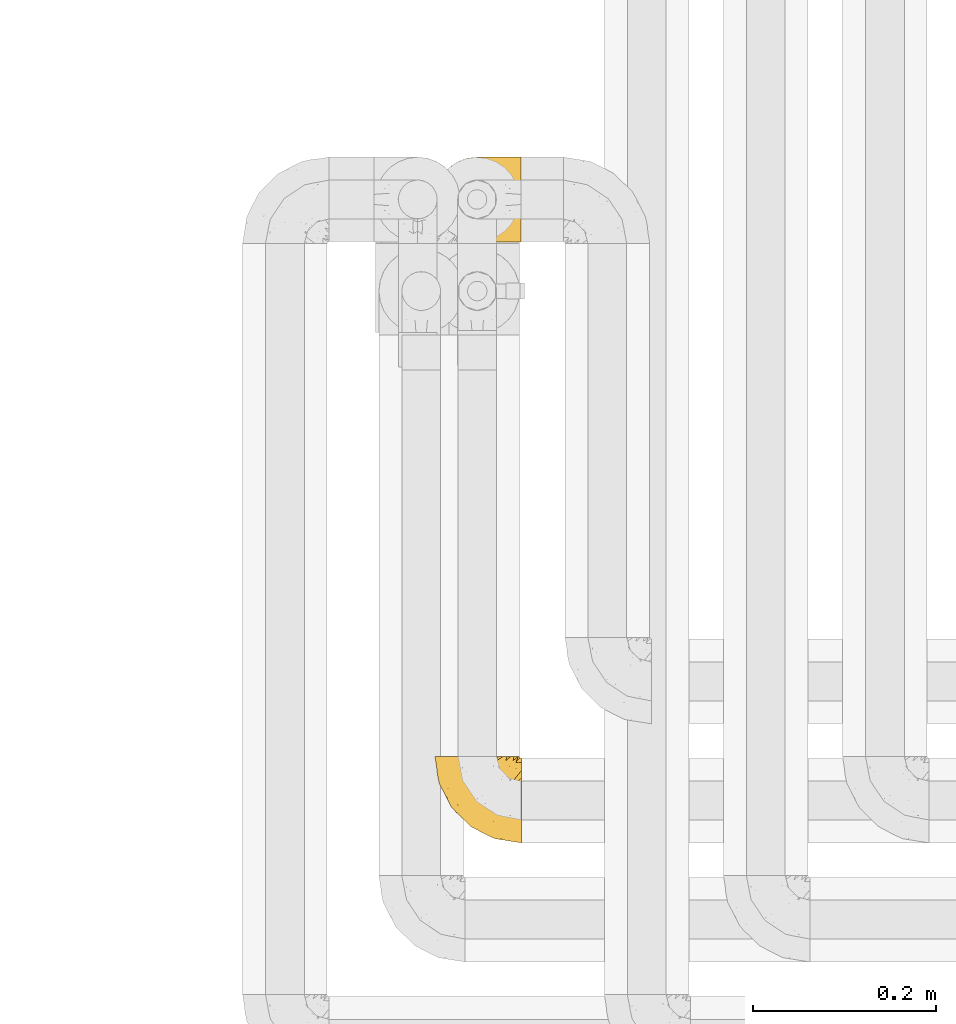
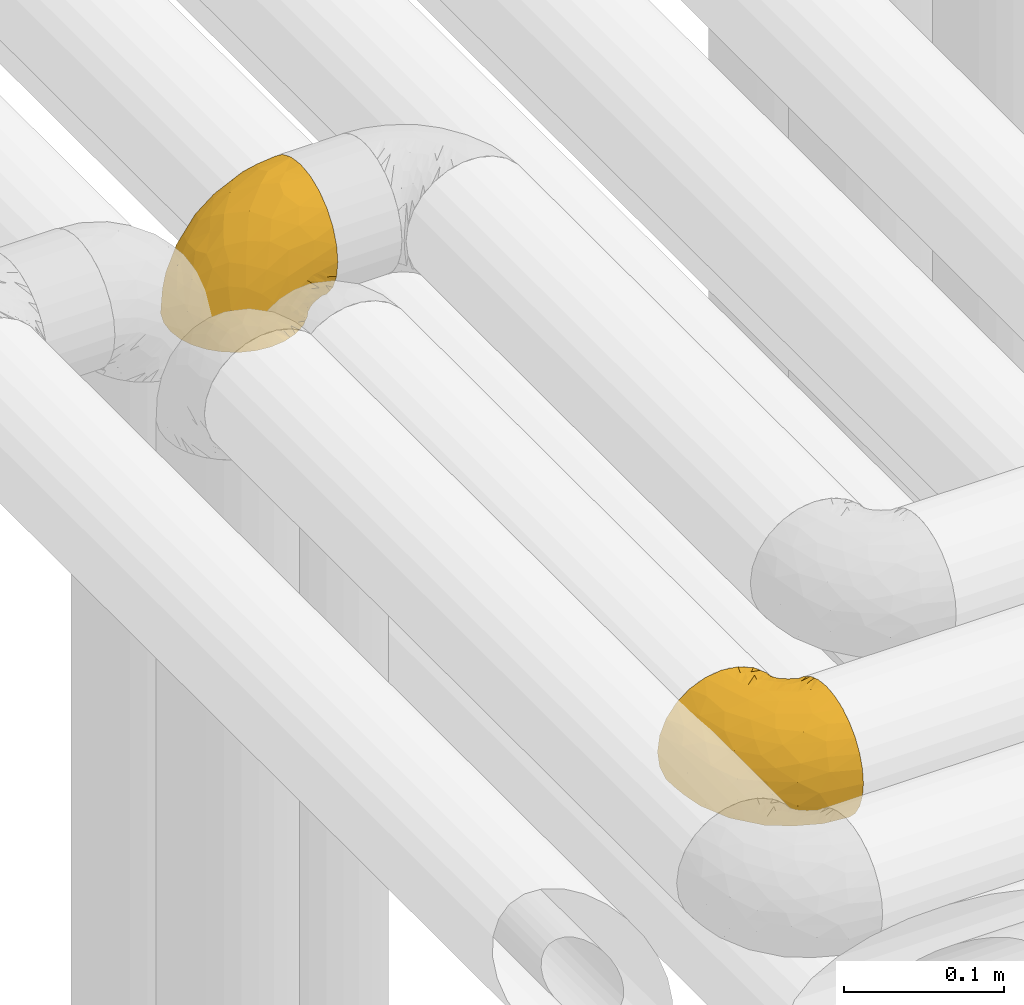
# One storey, part 236 of 827: 2 coverings.
"""IFC2X3 building model written with IfcOpenShell, lengths in millimetres."""

from ifc_helpers import new_model, entity, si_unit, converted_unit, derived_unit, direction, frame, origin, place, context, subcontext, project, spatial, faceted_brep, element, save


model = new_model("IFC2X3")

# Units and contexts
model_context = context("Model", 3, precision=0.01, world=origin(), true_north=direction((6.12303176911189e-17, 1.0)))
body_context = subcontext(model_context, "Body", "Model", "MODEL_VIEW")
ifc_project = project(units=[si_unit("LENGTHUNIT", "METRE", prefix="MILLI"), si_unit("AREAUNIT", "SQUARE_METRE"), si_unit("VOLUMEUNIT", "CUBIC_METRE"), converted_unit("PLANEANGLEUNIT", "DEGREE", entity("IfcRatioMeasure", 0.0174532925199433), si_unit("PLANEANGLEUNIT", "RADIAN"), dimensions=[0, 0, 0, 0, 0, 0, 0]), si_unit("MASSUNIT", "GRAM", prefix="KILO"), derived_unit("MASSDENSITYUNIT", [(si_unit("MASSUNIT", "GRAM", prefix="KILO"), 1), (si_unit("LENGTHUNIT", "METRE"), -3)]), derived_unit("MOMENTOFINERTIAUNIT", [(si_unit("LENGTHUNIT", "METRE"), 4)]), si_unit("TIMEUNIT", "SECOND"), si_unit("FREQUENCYUNIT", "HERTZ"), si_unit("THERMODYNAMICTEMPERATUREUNIT", "DEGREE_CELSIUS"), derived_unit("THERMALTRANSMITTANCEUNIT", [(si_unit("MASSUNIT", "GRAM", prefix="KILO"), 1), (si_unit("THERMODYNAMICTEMPERATUREUNIT", "KELVIN"), -1), (si_unit("TIMEUNIT", "SECOND"), -3)]), derived_unit("VOLUMETRICFLOWRATEUNIT", [(si_unit("LENGTHUNIT", "METRE"), 3), (si_unit("TIMEUNIT", "SECOND"), -1)]), derived_unit("MASSFLOWRATEUNIT", [(si_unit("MASSUNIT", "GRAM", prefix="KILO"), 1), (si_unit("TIMEUNIT", "SECOND"), -1)]), derived_unit("ROTATIONALFREQUENCYUNIT", [(si_unit("TIMEUNIT", "SECOND"), -1)]), si_unit("ELECTRICCURRENTUNIT", "AMPERE"), si_unit("ELECTRICVOLTAGEUNIT", "VOLT"), si_unit("POWERUNIT", "WATT"), si_unit("FORCEUNIT", "NEWTON", prefix="KILO"), si_unit("ILLUMINANCEUNIT", "LUX"), si_unit("LUMINOUSFLUXUNIT", "LUMEN"), si_unit("LUMINOUSINTENSITYUNIT", "CANDELA"), derived_unit("USERDEFINED", [(si_unit("MASSUNIT", "GRAM", prefix="KILO"), -1), (si_unit("LENGTHUNIT", "METRE"), -2), (si_unit("TIMEUNIT", "SECOND"), 3), (si_unit("LUMINOUSFLUXUNIT", "LUMEN"), 1)]), derived_unit("LINEARVELOCITYUNIT", [(si_unit("LENGTHUNIT", "METRE"), 1), (si_unit("TIMEUNIT", "SECOND"), -1)]), si_unit("PRESSUREUNIT", "PASCAL"), derived_unit("USERDEFINED", [(si_unit("LENGTHUNIT", "METRE"), -2), (si_unit("MASSUNIT", "GRAM", prefix="KILO"), 1), (si_unit("TIMEUNIT", "SECOND"), -2)]), derived_unit("LINEARFORCEUNIT", [(si_unit("MASSUNIT", "GRAM", prefix="KILO"), 1), (si_unit("LENGTHUNIT", "METRE"), 1), (si_unit("TIMEUNIT", "SECOND"), -2), (si_unit("LENGTHUNIT", "METRE"), -1)]), derived_unit("PLANARFORCEUNIT", [(si_unit("MASSUNIT", "GRAM", prefix="KILO"), 1), (si_unit("LENGTHUNIT", "METRE"), 1), (si_unit("TIMEUNIT", "SECOND"), -2), (si_unit("LENGTHUNIT", "METRE"), -2)])], contexts=[model_context])

# Site, building, storey
site_placement = place(None, origin())
site = spatial("IfcSite", under=ifc_project, at=site_placement, CompositionType="ELEMENT")
building_placement = place(site_placement, origin())
building = spatial("IfcBuilding", under=site, at=building_placement, CompositionType="ELEMENT")
storey_placement = place(building_placement, frame((0.0, 0.0, 28200.0)))
storey = spatial("IfcBuildingStorey", under=building, at=storey_placement, Name="08", CompositionType="ELEMENT", Elevation=28200.0)

# Coverings
covering_1_placement = place(storey_placement, frame((30683.75, 14312.21, 3352.2)))
element("IfcCovering", 1, at=covering_1_placement, inside=storey, Name=":ADSK_", ObjectType=":ADSK_", PredefinedType="INSULATION", context=body_context, shape_type="Brep", body=[
    faceted_brep([(95.8, 18.98, 83.91), (95.8, 11.67, 76.59), (95.8, 6.17, 67.83), (95.8, 2.75, 58.07), (95.8, 1.6, 47.8), (95.8, 2.75, 37.51), (95.8, 6.17, 27.74), (95.8, 11.68, 18.98), (95.8, 19.0, 11.67), (95.8, 27.76, 6.17), (95.8, 37.52, 2.75), (95.8, 47.8, 1.6), (95.8, 51.94, 2.06), (95.8, 55.01, 2.41), (95.8, 58.08, 2.75), (95.8, 62.96, 4.46), (95.8, 67.85, 6.17), (95.8, 72.23, 8.93), (95.8, 76.61, 11.68), (95.8, 80.26, 15.34), (95.8, 83.92, 19.0), (95.8, 89.42, 27.76), (95.8, 91.13, 32.64), (95.8, 92.84, 37.52), (95.8, 94.0, 47.8), (95.8, 92.84, 58.08), (95.8, 91.13, 62.96), (95.8, 89.42, 67.85), (95.8, 83.91, 76.61), (95.8, 80.25, 80.26), (95.8, 76.59, 83.92), (95.8, 72.21, 86.67), (95.8, 67.83, 89.42), (95.8, 62.95, 91.13), (95.8, 58.07, 92.84), (95.8, 55.0, 93.18), (95.8, 51.94, 93.53), (95.8, 47.8, 94.0), (95.8, 37.51, 92.84), (95.8, 27.74, 89.42), (94.0, 95.8, 47.8), (92.42, 95.8, 35.84), (87.81, 95.8, 24.7), (84.13, 95.8, 19.91), (80.46, 95.8, 15.13), (75.68, 95.8, 11.46), (70.9, 95.8, 7.78), (65.32, 95.8, 5.48), (59.75, 95.8, 3.17), (56.14, 95.8, 2.69), (54.06, 95.8, 2.42), (51.97, 95.8, 2.14), (47.8, 95.8, 1.6), (35.84, 95.8, 3.17), (24.7, 95.8, 7.78), (15.13, 95.8, 15.13), (7.78, 95.8, 24.7), (3.17, 95.8, 35.84), (1.6, 95.8, 47.8), (3.17, 95.8, 59.75), (7.78, 95.8, 70.9), (15.13, 95.8, 80.46), (24.7, 95.8, 87.81), (35.84, 95.8, 92.42), (47.8, 95.8, 94.0), (51.97, 95.8, 93.45), (56.14, 95.8, 92.9), (59.75, 95.8, 92.42), (65.32, 95.8, 90.11), (70.9, 95.8, 87.81), (75.68, 95.8, 84.13), (80.46, 95.8, 80.46), (84.13, 95.8, 75.68), (87.81, 95.8, 70.9), (92.42, 95.8, 59.75), (15.84, 60.58, 71.98), (6.99, 74.11, 63.6), (14.39, 51.59, 59.72), (6.21, 66.69, 47.8), (4.26, 76.19, 55.16), (3.39, 84.43, 47.8), (31.2, 31.2, 63.76), (26.47, 42.88, 72.22), (11.44, 79.41, 74.18), (47.66, 60.7, 92.52), (61.85, 61.85, 94.0), (59.25, 65.75, 94.0), (56.65, 69.64, 94.0), (54.05, 73.53, 94.0), (51.45, 77.43, 94.0), (19.8, 74.59, 82.14), (26.22, 54.72, 80.34), (31.58, 64.18, 87.52), (38.36, 37.94, 79.59), (51.54, 25.89, 78.25), (51.6, 34.73, 85.01), (55.97, 42.89, 90.25), (62.88, 49.83, 93.2), (41.35, 48.58, 87.23), (82.24, 22.41, 85.55), (40.88, 78.69, 93.0), (29.0, 81.64, 89.31), (74.06, 6.22, 61.31), (54.53, 12.11, 56.86), (57.98, 14.81, 68.34), (43.81, 21.61, 65.71), (38.22, 22.41, 56.99), (38.33, 30.12, 72.15), (74.76, 10.01, 70.34), (76.85, 15.36, 78.36), (84.43, 3.39, 47.8), (40.43, 19.59, 47.8), (30.01, 30.01, 47.8), (78.67, 41.19, 93.06), (92.06, 48.54, 94.0), (88.32, 49.28, 94.0), (85.6, 49.82, 94.0), (82.88, 50.37, 94.0), (80.15, 50.91, 94.0), (77.43, 51.45, 94.0), (76.36, 31.61, 89.88), (50.91, 80.15, 94.0), (50.37, 82.88, 94.0), (49.82, 85.6, 94.0), (49.28, 88.32, 94.0), (48.91, 90.19, 94.0), (48.54, 92.06, 94.0), (66.69, 6.21, 47.8), (73.53, 54.05, 94.0), (69.64, 56.65, 94.0), (65.75, 59.25, 94.0), (66.13, 24.66, 83.7), (19.59, 40.43, 47.8), (24.64, 35.17, 55.9), (53.56, 12.9, 47.8), (12.9, 53.56, 47.8), (82.81, 85.34, 81.75), (81.22, 78.44, 86.43), (86.57, 84.37, 79.8), (92.75, 89.05, 69.84), (89.68, 82.76, 79.5), (72.26, 86.31, 88.08), (64.73, 83.73, 91.6), (62.45, 77.31, 92.93), (60.63, 87.78, 92.43), (56.91, 87.91, 93.24), (58.14, 81.29, 93.36), (93.7, 93.97, 57.25), (83.4, 70.76, 89.41), (75.54, 63.67, 92.89), (79.46, 62.62, 92.66), (82.28, 90.64, 79.58), (76.25, 84.08, 86.51), (90.18, 77.45, 83.91), (84.69, 76.28, 86.29), (65.12, 88.72, 90.94), (71.71, 71.28, 91.94), (75.21, 68.09, 91.98), (78.6, 91.07, 82.79), (87.27, 57.47, 93.16), (87.92, 70.34, 88.76), (86.94, 91.35, 73.94), (86.1, 62.99, 91.89), (94.52, 94.52, 47.8), (66.23, 76.47, 92.22), (91.08, 69.96, 88.56), (71.77, 89.86, 87.72), (76.21, 78.94, 88.33), (68.59, 73.51, 92.18), (89.94, 89.62, 71.78), (76.22, 78.96, 7.27), (81.22, 78.46, 9.17), (71.7, 71.31, 3.66), (48.54, 92.06, 1.6), (50.37, 82.88, 1.6), (49.82, 85.6, 1.6), (49.28, 88.32, 1.6), (93.7, 93.97, 38.35), (89.95, 89.63, 23.84), (82.88, 50.37, 1.6), (85.6, 49.82, 1.6), (92.06, 48.54, 1.6), (88.32, 49.28, 1.6), (89.68, 82.77, 16.1), (87.92, 70.36, 6.84), (62.45, 77.31, 2.66), (66.24, 76.47, 3.37), (56.65, 69.64, 1.6), (59.25, 65.75, 1.6), (78.6, 91.06, 12.8), (60.63, 87.78, 3.16), (56.91, 87.91, 2.35), (92.76, 89.06, 25.77), (76.25, 84.09, 9.09), (82.28, 90.65, 16.02), (82.81, 85.35, 13.85), (54.05, 73.53, 1.6), (51.45, 77.43, 1.6), (58.14, 81.29, 2.23), (90.18, 77.46, 11.69), (84.7, 76.29, 9.31), (87.25, 57.47, 2.43), (75.58, 63.71, 2.71), (75.2, 68.11, 3.61), (83.39, 70.77, 6.18), (90.73, 69.52, 6.77), (79.47, 62.64, 2.93), (86.94, 91.35, 21.66), (65.75, 59.25, 1.6), (86.75, 84.6, 16.09), (86.08, 62.98, 3.7), (77.43, 51.45, 1.6), (73.53, 54.05, 1.6), (69.64, 56.65, 1.6), (64.73, 83.73, 3.99), (50.91, 80.15, 1.6), (65.12, 88.72, 4.65), (72.26, 86.3, 7.51), (61.85, 61.85, 1.6), (68.62, 73.56, 3.43), (74.03, 91.36, 9.46), (80.15, 50.91, 1.6), (49.81, 62.87, 2.4), (4.26, 76.19, 40.43), (19.95, 73.57, 13.57), (30.61, 56.07, 11.3), (25.71, 49.77, 18.65), (22.43, 44.73, 27.26), (15.85, 60.58, 23.61), (60.69, 47.64, 3.07), (40.49, 78.32, 2.69), (14.39, 51.59, 35.87), (6.99, 74.11, 31.99), (29.56, 76.04, 6.71), (11.45, 79.41, 21.41), (57.98, 14.82, 27.24), (74.06, 6.22, 34.26), (54.52, 12.12, 38.73), (43.47, 23.51, 26.97), (31.2, 31.2, 31.83), (33.27, 34.96, 23.4), (64.26, 33.86, 6.91), (74.29, 38.94, 3.4), (80.41, 30.23, 5.84), (24.64, 35.17, 39.69), (73.62, 15.85, 17.6), (78.98, 22.59, 10.38), (53.69, 21.56, 20.6), (42.86, 55.94, 5.36), (41.67, 20.67, 35.73), (79.66, 9.19, 24.84), (58.41, 25.79, 13.87), (47.11, 41.16, 9.06), (38.37, 37.95, 15.99)], [[[0, 1, 2, 3, 4, 5, 6, 7, 8, 9, 10, 11, 12, 13, 14, 15, 16, 17, 18, 19, 20, 21, 22, 23, 24, 25, 26, 27, 28, 29, 30, 31, 32, 33, 34, 35, 36, 37, 38, 39]], [[40, 41, 42, 43, 44, 45, 46, 47, 48, 49, 50, 51, 52, 53, 54, 55, 56, 57, 58, 59, 60, 61, 62, 63, 64, 65, 66, 67, 68, 69, 70, 71, 72, 73, 74]], [[75, 76, 77]], [[78, 79, 80]], [[77, 81, 82]], [[76, 75, 83]], [[84, 85, 86, 87, 88, 89]], [[90, 91, 92]], [[76, 60, 59]], [[93, 94, 95]], [[90, 62, 61]], [[83, 61, 60]], [[96, 97, 84]], [[98, 93, 95]], [[0, 39, 99]], [[100, 84, 89]], [[62, 101, 63]], [[2, 102, 3]], [[92, 84, 100]], [[103, 102, 104]], [[103, 105, 106]], [[93, 107, 94]], [[1, 108, 2]], [[92, 101, 90]], [[108, 1, 109]], [[102, 110, 3]], [[93, 82, 107]], [[102, 108, 104]], [[111, 106, 112]], [[109, 0, 99]], [[113, 37, 114, 115, 116, 117, 118, 119]], [[120, 38, 113]], [[100, 89, 121, 122, 123, 124, 125, 126, 64]], [[127, 102, 103]], [[97, 119, 128, 129, 130, 85]], [[99, 120, 131]], [[132, 133, 77]], [[59, 80, 79]], [[1, 0, 109]], [[98, 84, 92]], [[94, 109, 131]], [[120, 39, 38]], [[93, 91, 82]], [[104, 94, 105]], [[97, 113, 119]], [[95, 120, 96]], [[83, 90, 61]], [[91, 93, 98]], [[64, 63, 100]], [[100, 63, 101]], [[77, 76, 79]], [[133, 106, 81]], [[84, 97, 85]], [[113, 96, 120]], [[113, 97, 96]], [[37, 113, 38]], [[110, 102, 127]], [[110, 4, 3]], [[103, 111, 134, 127]], [[90, 75, 91]], [[82, 81, 107]], [[91, 75, 82]], [[77, 82, 75]], [[76, 83, 60]], [[90, 83, 75]], [[105, 107, 81]], [[94, 131, 95]], [[105, 94, 107]], [[109, 94, 104]], [[120, 95, 131]], [[98, 95, 96]], [[84, 98, 96]], [[98, 92, 91]], [[106, 105, 81]], [[103, 104, 105]], [[112, 106, 133]], [[103, 106, 111]], [[112, 133, 132]], [[81, 77, 133]], [[77, 78, 135, 132]], [[120, 99, 39]], [[109, 99, 131]], [[59, 58, 80]], [[59, 79, 76]], [[90, 101, 62]], [[100, 101, 92]], [[2, 108, 102]], [[109, 104, 108]], [[78, 77, 79]], [[136, 137, 138]], [[27, 139, 140]], [[141, 142, 143]], [[144, 145, 121]], [[146, 89, 88]], [[147, 139, 25]], [[148, 149, 150]], [[136, 151, 152]], [[147, 40, 74]], [[24, 147, 25]], [[153, 140, 154]], [[33, 116, 34]], [[73, 72, 151]], [[114, 37, 36, 35, 34, 116, 115]], [[146, 155, 144]], [[156, 85, 130]], [[157, 149, 148]], [[151, 158, 152]], [[117, 33, 159]], [[29, 153, 160]], [[161, 74, 73]], [[162, 128, 119]], [[66, 65, 64, 126, 125, 124, 123, 122, 67]], [[163, 147, 24]], [[27, 140, 28]], [[149, 129, 150]], [[139, 27, 26, 25]], [[68, 144, 69]], [[129, 128, 150]], [[164, 87, 86]], [[130, 129, 149]], [[122, 145, 67]], [[153, 154, 148]], [[162, 119, 159]], [[165, 30, 160]], [[150, 160, 148]], [[128, 162, 150]], [[30, 165, 31]], [[145, 144, 68]], [[89, 146, 144]], [[87, 164, 143]], [[166, 155, 142]], [[88, 87, 143]], [[162, 160, 150]], [[160, 30, 29]], [[160, 153, 148]], [[28, 140, 153]], [[29, 28, 153]], [[140, 137, 154]], [[157, 148, 154]], [[156, 130, 157]], [[154, 137, 157]], [[157, 137, 156]], [[167, 137, 136]], [[168, 85, 156]], [[152, 168, 167]], [[167, 168, 156]], [[164, 152, 141]], [[71, 158, 72]], [[152, 167, 136]], [[88, 142, 146]], [[144, 155, 69]], [[146, 142, 155]], [[70, 166, 71]], [[142, 141, 166]], [[70, 69, 155]], [[141, 158, 71]], [[161, 73, 151]], [[138, 137, 140]], [[161, 136, 169]], [[136, 161, 151]], [[74, 161, 169]], [[152, 158, 141]], [[151, 72, 158]], [[168, 152, 164]], [[137, 167, 156]], [[164, 86, 168]], [[85, 168, 86]], [[116, 33, 117]], [[130, 149, 157]], [[67, 145, 68]], [[121, 89, 144]], [[145, 122, 121]], [[40, 147, 163]], [[169, 147, 74]], [[159, 33, 32]], [[162, 159, 32]], [[159, 119, 118, 117]], [[139, 147, 169]], [[139, 169, 138]], [[162, 32, 31]], [[141, 143, 164]], [[88, 143, 142]], [[71, 166, 141]], [[155, 166, 70]], [[139, 138, 140]], [[169, 136, 138]], [[160, 162, 165]], [[162, 31, 165]], [[170, 171, 172]], [[173, 52, 51, 50, 49, 48, 174, 175, 176]], [[177, 178, 41]], [[179, 15, 180]], [[12, 11, 181, 182, 180, 14, 13]], [[183, 21, 20]], [[19, 18, 184]], [[185, 186, 187]], [[186, 188, 187]], [[43, 189, 44]], [[190, 191, 47]], [[23, 22, 21, 192]], [[193, 194, 195]], [[40, 163, 177]], [[196, 197, 198]], [[24, 23, 177]], [[199, 200, 183]], [[201, 15, 179]], [[47, 46, 190]], [[202, 203, 204]], [[203, 172, 171]], [[205, 206, 184]], [[207, 41, 178]], [[16, 15, 201]], [[14, 180, 15]], [[204, 203, 200]], [[208, 203, 202]], [[163, 24, 177]], [[48, 47, 191]], [[198, 197, 190]], [[199, 184, 204]], [[171, 195, 209]], [[210, 211, 212]], [[206, 212, 213]], [[205, 17, 210]], [[184, 206, 204]], [[210, 212, 206]], [[185, 196, 214]], [[190, 215, 191]], [[216, 45, 214]], [[186, 217, 193]], [[190, 216, 198]], [[199, 20, 19]], [[196, 185, 187]], [[199, 183, 20]], [[184, 199, 19]], [[199, 204, 200]], [[206, 202, 204]], [[171, 183, 200]], [[203, 208, 172]], [[172, 208, 218]], [[171, 200, 203]], [[218, 188, 219]], [[195, 170, 193]], [[217, 186, 185]], [[193, 219, 186]], [[193, 170, 219]], [[207, 194, 42]], [[217, 220, 189]], [[216, 190, 46]], [[214, 196, 198]], [[44, 220, 45]], [[214, 198, 216]], [[216, 46, 45]], [[214, 45, 220]], [[42, 194, 43]], [[189, 193, 217]], [[207, 195, 194]], [[209, 195, 178]], [[41, 207, 42]], [[195, 207, 178]], [[43, 194, 189]], [[193, 189, 194]], [[171, 170, 195]], [[170, 172, 219]], [[218, 219, 172]], [[188, 186, 219]], [[206, 213, 202]], [[208, 202, 213]], [[201, 210, 16]], [[215, 190, 197]], [[215, 174, 191]], [[174, 48, 191]], [[201, 179, 221, 211]], [[210, 201, 211]], [[23, 192, 177]], [[40, 177, 41]], [[183, 209, 192]], [[183, 192, 21]], [[192, 178, 177]], [[205, 18, 17]], [[17, 16, 210]], [[217, 185, 214]], [[189, 220, 44]], [[214, 220, 217]], [[192, 209, 178]], [[171, 209, 183]], [[206, 205, 210]], [[18, 205, 184]], [[222, 197, 196, 187, 188, 218]], [[57, 223, 80]], [[224, 225, 226]], [[226, 227, 228]], [[229, 218, 208, 213, 212, 211]], [[230, 52, 173, 176, 175, 174, 215, 197]], [[231, 232, 228]], [[231, 78, 223]], [[223, 57, 232]], [[224, 233, 225]], [[233, 54, 53]], [[234, 232, 56]], [[56, 55, 234]], [[234, 224, 228]], [[235, 236, 237]], [[224, 55, 54]], [[238, 239, 240]], [[52, 230, 53]], [[241, 242, 243]], [[231, 227, 244]], [[11, 10, 242]], [[236, 6, 5]], [[7, 245, 8]], [[8, 246, 9]], [[238, 247, 235]], [[222, 229, 248]], [[242, 211, 221, 179, 180, 182, 181, 11]], [[233, 53, 230]], [[111, 112, 249]], [[250, 6, 236]], [[246, 251, 241]], [[6, 250, 7]], [[127, 236, 110]], [[248, 229, 252]], [[246, 8, 245]], [[235, 245, 250]], [[236, 5, 110]], [[235, 249, 238]], [[237, 236, 127]], [[243, 9, 246]], [[252, 229, 241]], [[56, 232, 57]], [[222, 230, 197]], [[225, 248, 252]], [[248, 233, 230]], [[54, 233, 224]], [[231, 228, 227]], [[244, 132, 231]], [[248, 225, 233]], [[226, 225, 253]], [[235, 250, 236]], [[245, 7, 250]], [[251, 246, 245]], [[243, 246, 241]], [[247, 245, 235]], [[252, 251, 253]], [[229, 222, 218]], [[230, 222, 248]], [[5, 4, 110]], [[237, 127, 134, 111]], [[238, 249, 239]], [[224, 234, 55]], [[232, 234, 228]], [[242, 241, 229]], [[10, 9, 243]], [[211, 242, 229]], [[10, 243, 242]], [[80, 223, 78]], [[80, 58, 57]], [[231, 223, 232]], [[227, 240, 239]], [[224, 226, 228]], [[240, 226, 253]], [[227, 239, 244]], [[226, 240, 227]], [[251, 247, 253]], [[240, 253, 247]], [[249, 235, 237]], [[237, 111, 249]], [[244, 239, 249]], [[112, 244, 249]], [[135, 78, 231, 132]], [[112, 132, 244]], [[247, 238, 240]], [[245, 247, 251]], [[251, 252, 241]], [[225, 252, 253]]]),
])
covering_2_placement = place(storey_placement, frame((30683.5, 14968.41, 3350.4)))
element("IfcCovering", 2, at=covering_2_placement, inside=storey, Name=":ADSK_", ObjectType=":ADSK_", PredefinedType="INSULATION", context=body_context, shape_type="Brep", body=[
    faceted_brep([(18.98, 11.68, 1.6), (11.67, 19.0, 1.6), (6.17, 27.76, 1.6), (2.75, 37.52, 1.6), (1.6, 47.8, 1.6), (2.75, 58.08, 1.6), (6.17, 67.85, 1.6), (11.68, 76.61, 1.6), (19.0, 83.92, 1.6), (27.76, 89.42, 1.6), (37.52, 92.84, 1.6), (47.8, 94.0, 1.6), (51.94, 93.53, 1.6), (55.01, 93.18, 1.6), (58.08, 92.84, 1.6), (62.96, 91.13, 1.6), (67.85, 89.42, 1.6), (72.23, 86.66, 1.6), (76.61, 83.91, 1.6), (80.26, 80.25, 1.6), (83.92, 76.59, 1.6), (89.42, 67.83, 1.6), (91.13, 62.95, 1.6), (92.84, 58.07, 1.6), (94.0, 47.8, 1.6), (92.84, 37.51, 1.6), (91.13, 32.63, 1.6), (89.42, 27.74, 1.6), (83.91, 18.98, 1.6), (80.25, 15.33, 1.6), (76.59, 11.67, 1.6), (72.21, 8.92, 1.6), (67.83, 6.17, 1.6), (62.95, 4.46, 1.6), (58.07, 2.75, 1.6), (55.0, 2.41, 1.6), (51.94, 2.06, 1.6), (47.8, 1.6, 1.6), (37.51, 2.75, 1.6), (27.74, 6.17, 1.6), (95.8, 47.8, 3.4), (95.8, 59.75, 4.97), (95.8, 70.9, 9.58), (95.8, 75.68, 13.26), (95.8, 80.46, 16.93), (95.8, 84.13, 21.71), (95.8, 87.81, 26.5), (95.8, 90.11, 32.07), (95.8, 92.42, 37.64), (95.8, 92.9, 41.25), (95.8, 93.17, 43.34), (95.8, 93.45, 45.42), (95.8, 94.0, 49.6), (95.8, 92.42, 61.55), (95.8, 87.81, 72.7), (95.8, 80.46, 82.26), (95.8, 70.9, 89.61), (95.8, 59.75, 94.22), (95.8, 47.8, 95.8), (95.8, 35.84, 94.22), (95.8, 24.7, 89.61), (95.8, 15.13, 82.26), (95.8, 7.78, 72.7), (95.8, 3.17, 61.55), (95.8, 1.6, 49.6), (95.8, 2.14, 45.42), (95.8, 2.69, 41.25), (95.8, 3.17, 37.64), (95.8, 5.48, 32.07), (95.8, 7.78, 26.5), (95.8, 11.46, 21.71), (95.8, 15.13, 16.93), (95.8, 19.91, 13.26), (95.8, 24.7, 9.58), (95.8, 35.84, 4.97), (60.58, 23.61, 81.55), (74.11, 31.99, 90.4), (51.59, 35.87, 83.0), (66.69, 47.8, 91.18), (76.19, 40.43, 93.13), (84.43, 47.8, 94.0), (31.2, 31.83, 66.19), (42.88, 23.37, 70.92), (79.41, 21.41, 85.95), (60.7, 3.07, 49.74), (61.85, 1.6, 35.54), (65.75, 1.6, 38.14), (69.64, 1.6, 40.74), (73.53, 1.6, 43.34), (77.43, 1.6, 45.94), (74.59, 13.45, 77.59), (54.72, 15.25, 71.17), (64.18, 8.07, 65.81), (37.94, 16.0, 59.03), (25.89, 17.34, 45.85), (34.73, 10.58, 45.79), (42.89, 5.34, 41.42), (49.83, 2.39, 34.51), (48.58, 8.36, 56.04), (22.41, 10.04, 15.15), (78.69, 2.59, 56.51), (81.64, 6.28, 68.39), (6.22, 34.28, 23.33), (12.11, 38.73, 42.86), (14.81, 27.25, 39.42), (21.61, 29.88, 53.58), (22.41, 38.6, 59.17), (30.12, 23.44, 59.06), (10.01, 25.25, 22.63), (15.36, 17.23, 20.55), (3.39, 47.8, 12.96), (19.59, 47.8, 56.96), (30.01, 47.8, 67.38), (41.19, 2.53, 18.72), (48.54, 1.6, 5.33), (49.28, 1.6, 9.07), (49.82, 1.6, 11.79), (50.37, 1.6, 14.51), (50.91, 1.6, 17.24), (51.45, 1.6, 19.96), (31.61, 5.71, 21.03), (80.15, 1.6, 46.48), (82.88, 1.6, 47.03), (85.6, 1.6, 47.57), (88.32, 1.6, 48.11), (90.19, 1.6, 48.48), (92.06, 1.6, 48.85), (6.21, 47.8, 30.7), (54.05, 1.6, 23.86), (56.65, 1.6, 27.75), (59.25, 1.6, 31.64), (24.66, 11.89, 31.26), (40.43, 47.8, 77.8), (35.17, 39.69, 72.75), (12.9, 47.8, 43.83), (53.56, 47.8, 84.49), (85.34, 13.84, 14.58), (78.44, 9.16, 16.17), (84.37, 15.79, 10.82), (89.05, 25.75, 4.64), (82.76, 16.09, 7.71), (86.31, 7.51, 25.13), (83.73, 3.99, 32.66), (77.31, 2.66, 34.94), (87.78, 3.16, 36.76), (87.91, 2.35, 40.48), (81.29, 2.23, 39.25), (93.97, 38.35, 3.69), (70.76, 6.18, 13.99), (63.67, 2.7, 21.85), (62.62, 2.93, 17.93), (90.64, 16.01, 15.11), (84.08, 9.08, 21.14), (76.28, 9.3, 12.7), (77.45, 11.68, 7.21), (88.72, 4.65, 32.27), (71.28, 3.65, 25.68), (68.09, 3.61, 22.18), (91.07, 12.8, 18.79), (57.47, 2.43, 10.12), (70.34, 6.83, 9.47), (91.35, 21.65, 10.45), (62.99, 3.7, 11.29), (94.52, 47.8, 2.87), (76.47, 3.37, 31.16), (69.96, 7.03, 6.31), (89.86, 7.87, 25.62), (78.94, 7.26, 21.18), (73.51, 3.41, 28.81), (89.62, 23.81, 7.45), (84.09, 86.5, 21.14), (86.3, 88.08, 25.13), (91.06, 82.79, 18.79), (88.32, 94.0, 48.11), (92.06, 94.0, 48.85), (82.88, 94.0, 47.03), (85.6, 94.0, 47.57), (93.97, 57.24, 3.69), (89.63, 71.76, 7.44), (50.37, 94.0, 14.51), (49.82, 94.0, 11.79), (48.54, 94.0, 5.33), (49.28, 94.0, 9.07), (82.77, 79.49, 7.71), (70.36, 88.75, 9.47), (77.31, 92.93, 34.94), (76.47, 92.22, 31.16), (69.64, 94.0, 40.74), (65.75, 94.0, 38.14), (87.78, 92.43, 36.76), (87.91, 93.24, 40.48), (89.06, 69.82, 4.63), (90.65, 79.57, 15.11), (85.35, 81.74, 14.58), (73.53, 94.0, 43.34), (77.43, 94.0, 45.94), (81.29, 93.36, 39.25), (77.46, 83.9, 7.21), (76.29, 86.28, 12.69), (57.47, 93.16, 10.14), (63.71, 92.88, 21.81), (68.11, 91.98, 22.19), (70.77, 89.41, 14.0), (71.31, 91.93, 25.69), (78.46, 86.42, 16.17), (69.52, 88.82, 6.66), (62.64, 92.66, 17.92), (91.35, 73.93, 10.45), (59.25, 94.0, 31.64), (84.6, 79.5, 10.64), (62.98, 91.89, 11.31), (51.45, 94.0, 19.96), (54.05, 94.0, 23.86), (56.65, 94.0, 27.75), (83.73, 91.6, 32.66), (80.15, 94.0, 46.48), (88.72, 90.94, 32.27), (61.85, 94.0, 35.54), (73.56, 92.16, 28.77), (78.96, 88.32, 21.17), (91.36, 86.13, 23.36), (50.91, 94.0, 17.24), (62.87, 93.2, 47.58), (76.19, 55.16, 93.13), (73.57, 82.02, 77.44), (56.07, 84.29, 66.78), (49.77, 76.94, 71.68), (44.73, 68.33, 74.96), (60.58, 71.98, 81.55), (47.64, 92.52, 36.7), (78.32, 92.9, 56.9), (51.59, 59.72, 83.0), (74.11, 63.6, 90.4), (76.04, 88.89, 67.83), (79.41, 74.18, 85.95), (14.82, 68.35, 39.41), (6.22, 61.33, 23.33), (12.12, 56.86, 42.87), (23.51, 68.62, 53.92), (31.2, 63.76, 66.19), (34.96, 72.19, 64.12), (33.86, 88.69, 33.13), (38.94, 92.19, 23.1), (30.23, 89.75, 16.98), (35.17, 55.9, 72.75), (15.85, 77.99, 23.77), (22.59, 85.21, 18.41), (21.56, 74.99, 43.7), (55.94, 90.23, 54.53), (20.67, 59.86, 55.72), (9.19, 70.75, 17.73), (25.79, 81.72, 38.98), (41.16, 86.53, 50.28), (37.95, 79.6, 59.02)], [[[0, 1, 2, 3, 4, 5, 6, 7, 8, 9, 10, 11, 12, 13, 14, 15, 16, 17, 18, 19, 20, 21, 22, 23, 24, 25, 26, 27, 28, 29, 30, 31, 32, 33, 34, 35, 36, 37, 38, 39]], [[40, 41, 42, 43, 44, 45, 46, 47, 48, 49, 50, 51, 52, 53, 54, 55, 56, 57, 58, 59, 60, 61, 62, 63, 64, 65, 66, 67, 68, 69, 70, 71, 72, 73, 74]], [[75, 76, 77]], [[78, 79, 80]], [[77, 81, 82]], [[76, 75, 83]], [[84, 85, 86, 87, 88, 89]], [[90, 91, 92]], [[76, 60, 59]], [[93, 94, 95]], [[90, 62, 61]], [[83, 61, 60]], [[96, 97, 84]], [[98, 93, 95]], [[0, 39, 99]], [[100, 84, 89]], [[62, 101, 63]], [[2, 102, 3]], [[92, 84, 100]], [[103, 102, 104]], [[103, 105, 106]], [[93, 107, 94]], [[1, 108, 2]], [[92, 101, 90]], [[108, 1, 109]], [[102, 110, 3]], [[93, 82, 107]], [[102, 108, 104]], [[111, 106, 112]], [[109, 0, 99]], [[113, 37, 114, 115, 116, 117, 118, 119]], [[120, 38, 113]], [[100, 89, 121, 122, 123, 124, 125, 126, 64]], [[127, 102, 103]], [[97, 119, 128, 129, 130, 85]], [[99, 120, 131]], [[132, 133, 77]], [[59, 80, 79]], [[1, 0, 109]], [[98, 84, 92]], [[94, 109, 131]], [[120, 39, 38]], [[93, 91, 82]], [[104, 94, 105]], [[97, 113, 119]], [[95, 120, 96]], [[83, 90, 61]], [[91, 93, 98]], [[64, 63, 100]], [[100, 63, 101]], [[77, 76, 79]], [[133, 106, 81]], [[84, 97, 85]], [[113, 96, 120]], [[113, 97, 96]], [[37, 113, 38]], [[110, 102, 127]], [[110, 4, 3]], [[103, 111, 134, 127]], [[90, 75, 91]], [[82, 81, 107]], [[91, 75, 82]], [[77, 82, 75]], [[76, 83, 60]], [[90, 83, 75]], [[105, 107, 81]], [[94, 131, 95]], [[105, 94, 107]], [[109, 94, 104]], [[120, 95, 131]], [[98, 95, 96]], [[84, 98, 96]], [[98, 92, 91]], [[106, 105, 81]], [[103, 104, 105]], [[112, 106, 133]], [[103, 106, 111]], [[112, 133, 132]], [[81, 77, 133]], [[77, 78, 135, 132]], [[120, 99, 39]], [[109, 99, 131]], [[59, 58, 80]], [[59, 79, 76]], [[90, 101, 62]], [[100, 101, 92]], [[2, 108, 102]], [[109, 104, 108]], [[78, 77, 79]], [[136, 137, 138]], [[27, 139, 140]], [[141, 142, 143]], [[144, 145, 121]], [[146, 89, 88]], [[147, 139, 25]], [[148, 149, 150]], [[136, 151, 152]], [[147, 40, 74]], [[24, 147, 25]], [[140, 153, 154]], [[33, 116, 34]], [[73, 72, 151]], [[114, 37, 36, 35, 34, 116, 115]], [[146, 155, 144]], [[156, 85, 130]], [[157, 149, 148]], [[151, 158, 152]], [[117, 33, 159]], [[29, 154, 160]], [[161, 74, 73]], [[162, 128, 119]], [[66, 65, 64, 126, 125, 124, 123, 122, 67]], [[163, 147, 24]], [[27, 140, 28]], [[149, 129, 150]], [[139, 27, 26, 25]], [[68, 144, 69]], [[129, 128, 150]], [[164, 87, 86]], [[130, 129, 149]], [[122, 145, 67]], [[154, 153, 148]], [[162, 119, 159]], [[165, 30, 160]], [[150, 160, 148]], [[128, 162, 150]], [[30, 165, 31]], [[145, 144, 68]], [[89, 146, 144]], [[87, 164, 143]], [[166, 155, 142]], [[88, 87, 143]], [[162, 160, 150]], [[160, 30, 29]], [[154, 29, 28]], [[140, 154, 28]], [[160, 154, 148]], [[140, 137, 153]], [[157, 148, 153]], [[156, 130, 157]], [[153, 137, 157]], [[157, 137, 156]], [[167, 137, 136]], [[168, 85, 156]], [[152, 168, 167]], [[167, 168, 156]], [[164, 152, 141]], [[71, 158, 72]], [[152, 167, 136]], [[88, 142, 146]], [[144, 155, 69]], [[146, 142, 155]], [[70, 166, 71]], [[142, 141, 166]], [[70, 69, 155]], [[141, 158, 71]], [[161, 73, 151]], [[138, 137, 140]], [[161, 136, 169]], [[136, 161, 151]], [[74, 161, 169]], [[152, 158, 141]], [[151, 72, 158]], [[168, 152, 164]], [[137, 167, 156]], [[164, 86, 168]], [[85, 168, 86]], [[116, 33, 117]], [[130, 149, 157]], [[67, 145, 68]], [[121, 89, 144]], [[145, 122, 121]], [[40, 147, 163]], [[169, 147, 74]], [[159, 33, 32]], [[162, 159, 32]], [[159, 119, 118, 117]], [[139, 147, 169]], [[139, 169, 138]], [[162, 32, 31]], [[141, 143, 164]], [[88, 143, 142]], [[71, 166, 141]], [[155, 166, 70]], [[139, 138, 140]], [[169, 136, 138]], [[160, 162, 165]], [[162, 31, 165]], [[170, 171, 172]], [[173, 174, 52, 51, 50, 49, 48, 175, 176]], [[177, 178, 41]], [[179, 15, 180]], [[12, 11, 181, 182, 180, 14, 13]], [[183, 21, 20]], [[19, 18, 184]], [[185, 186, 187]], [[186, 188, 187]], [[43, 172, 44]], [[189, 190, 47]], [[23, 22, 21, 191]], [[170, 192, 193]], [[40, 163, 177]], [[194, 195, 196]], [[24, 23, 177]], [[197, 198, 183]], [[199, 15, 179]], [[47, 46, 189]], [[200, 201, 202]], [[201, 203, 204]], [[205, 206, 184]], [[207, 41, 178]], [[16, 15, 199]], [[14, 180, 15]], [[202, 201, 198]], [[208, 201, 200]], [[163, 24, 177]], [[48, 47, 190]], [[196, 195, 189]], [[197, 184, 202]], [[204, 193, 209]], [[210, 211, 212]], [[206, 212, 213]], [[205, 17, 210]], [[184, 206, 202]], [[210, 212, 206]], [[185, 194, 214]], [[189, 215, 190]], [[216, 45, 214]], [[186, 171, 170]], [[189, 216, 196]], [[197, 20, 19]], [[194, 185, 187]], [[197, 183, 20]], [[184, 197, 19]], [[197, 202, 198]], [[206, 200, 202]], [[204, 183, 198]], [[201, 208, 203]], [[203, 208, 217]], [[204, 198, 201]], [[217, 188, 218]], [[193, 219, 170]], [[171, 186, 185]], [[170, 218, 186]], [[170, 219, 218]], [[42, 207, 192]], [[171, 220, 172]], [[216, 189, 46]], [[214, 194, 196]], [[44, 220, 45]], [[214, 196, 216]], [[216, 46, 45]], [[214, 45, 220]], [[192, 43, 42]], [[204, 203, 219]], [[207, 193, 192]], [[209, 193, 178]], [[41, 207, 42]], [[193, 207, 178]], [[43, 192, 172]], [[170, 172, 192]], [[204, 219, 193]], [[219, 203, 218]], [[217, 218, 203]], [[188, 186, 218]], [[206, 213, 200]], [[208, 200, 213]], [[199, 210, 16]], [[215, 189, 195]], [[215, 175, 190]], [[175, 48, 190]], [[199, 179, 221, 211]], [[210, 199, 211]], [[23, 191, 177]], [[40, 177, 41]], [[178, 177, 191]], [[21, 183, 191]], [[209, 191, 183]], [[205, 18, 17]], [[17, 16, 210]], [[171, 185, 214]], [[172, 220, 44]], [[214, 220, 171]], [[191, 209, 178]], [[204, 209, 183]], [[206, 205, 210]], [[18, 205, 184]], [[222, 195, 194, 187, 188, 217]], [[57, 223, 80]], [[224, 225, 226]], [[226, 227, 228]], [[229, 217, 208, 213, 212, 211]], [[230, 52, 174, 173, 176, 175, 215, 195]], [[231, 232, 228]], [[231, 78, 223]], [[223, 57, 232]], [[224, 233, 225]], [[233, 54, 53]], [[234, 232, 56]], [[56, 55, 234]], [[234, 224, 228]], [[235, 236, 237]], [[224, 55, 54]], [[238, 239, 240]], [[52, 230, 53]], [[241, 242, 243]], [[227, 244, 231]], [[11, 10, 242]], [[236, 6, 5]], [[7, 245, 8]], [[8, 246, 9]], [[238, 247, 235]], [[222, 229, 248]], [[242, 211, 221, 179, 180, 182, 181, 11]], [[233, 53, 230]], [[111, 112, 249]], [[250, 6, 236]], [[246, 251, 241]], [[6, 250, 7]], [[127, 236, 110]], [[248, 229, 252]], [[246, 8, 245]], [[235, 245, 250]], [[236, 5, 110]], [[235, 249, 238]], [[237, 236, 127]], [[243, 9, 246]], [[252, 229, 241]], [[56, 232, 57]], [[222, 230, 195]], [[225, 248, 252]], [[248, 233, 230]], [[54, 233, 224]], [[231, 228, 227]], [[244, 132, 231]], [[248, 225, 233]], [[226, 225, 253]], [[235, 250, 236]], [[245, 7, 250]], [[251, 246, 245]], [[243, 246, 241]], [[247, 245, 235]], [[252, 251, 253]], [[229, 222, 217]], [[230, 222, 248]], [[5, 4, 110]], [[237, 127, 134, 111]], [[238, 249, 239]], [[224, 234, 55]], [[232, 234, 228]], [[242, 241, 229]], [[10, 9, 243]], [[211, 242, 229]], [[10, 243, 242]], [[80, 223, 78]], [[80, 58, 57]], [[231, 223, 232]], [[227, 240, 239]], [[224, 226, 228]], [[240, 226, 253]], [[227, 239, 244]], [[226, 240, 227]], [[251, 247, 253]], [[240, 253, 247]], [[249, 235, 237]], [[237, 111, 249]], [[112, 132, 244]], [[112, 244, 249]], [[78, 231, 132, 135]], [[249, 244, 239]], [[247, 238, 240]], [[245, 247, 251]], [[251, 252, 241]], [[225, 252, 253]]]),
])

save(model, "model.ifc")
